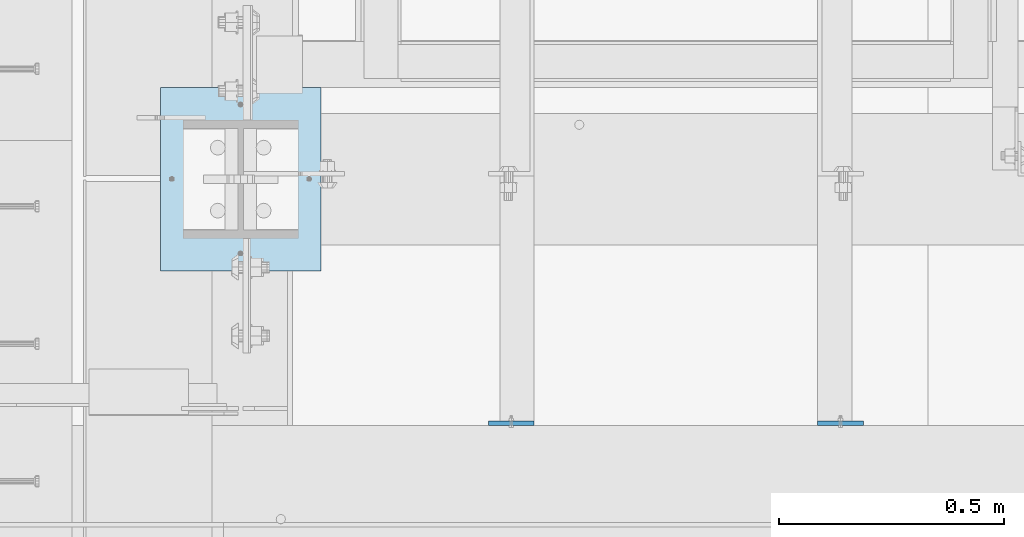
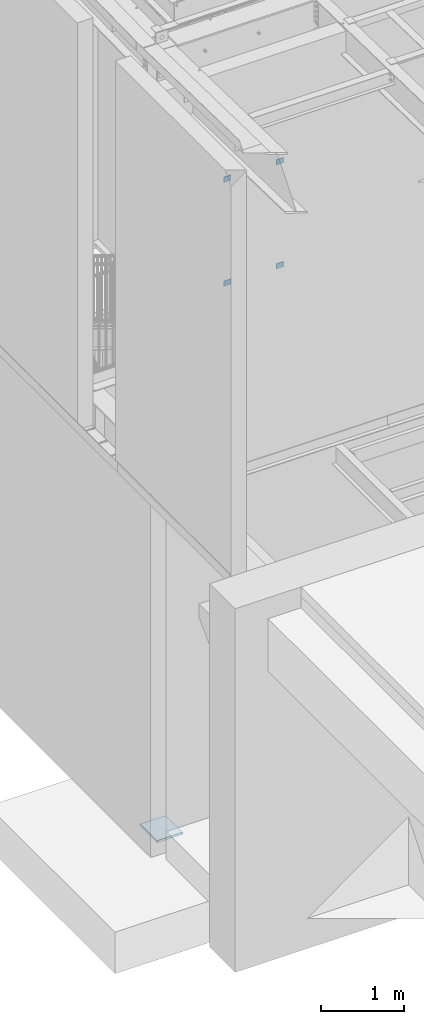
# One storey, part 1506 of 1763: 5 plates, 2 elements without a shape of their own.
"""IFC2X3 building model written with IfcOpenShell, lengths in millimetres."""

from ifc_helpers import new_model, si_unit, frame, origin_with_axes, place, context, subcontext, project, spatial, faceted_brep, material, type_object, element, aggregate, save


model = new_model("IFC2X3")

# Units and contexts
model_context = context("Model", 3, precision=1e-05, world=origin_with_axes())
body_context = subcontext(model_context, "Body", "Model", "MODEL_VIEW")
ifc_project = project(units=[si_unit("LENGTHUNIT", "METRE", prefix="MILLI"), si_unit("AREAUNIT", "SQUARE_METRE"), si_unit("VOLUMEUNIT", "CUBIC_METRE"), si_unit("MASSUNIT", "GRAM", prefix="KILO"), si_unit("TIMEUNIT", "SECOND"), si_unit("PLANEANGLEUNIT", "RADIAN"), si_unit("SOLIDANGLEUNIT", "STERADIAN"), si_unit("THERMODYNAMICTEMPERATUREUNIT", "DEGREE_CELSIUS"), si_unit("LUMINOUSINTENSITYUNIT", "LUMEN")], contexts=[model_context])

# Site, building, storey
site_placement = place(None, origin_with_axes())
site = spatial("IfcSite", under=ifc_project, at=site_placement, CompositionType="ELEMENT")
building_placement = place(site_placement, origin_with_axes())
building = spatial("IfcBuilding", under=site, at=building_placement, Name="Undefined", CompositionType="ELEMENT")
storey_placement = place(building_placement, origin_with_axes())
storey = spatial("IfcBuildingStorey", under=building, at=storey_placement, Name="Undefined", CompositionType="ELEMENT", Elevation=0.0)

# Assembly, plates
assembly_1_placement = place(storey_placement, origin_with_axes())
assembly_1 = element("IfcElementAssembly", 1, at=assembly_1_placement, inside=storey, Name="LADDER", AssemblyPlace="NOTDEFINED", PredefinedType="RIGID_FRAME")
ifc_material = material(Name="STEEL/A36")
plate_type_1 = type_object("IfcPlateType", PredefinedType="NOTDEFINED")
plate_1_placement = place(assembly_1_placement, frame((-86724.5624669171, 29481.4624999971, 9448.8), z_axis=(0.0, 0.0, -1.0), x_axis=(-1.0, 0.0, 0.0)))
plate_1 = element("IfcPlate", 2, at=plate_1_placement, type_object=plate_type_1, material=ifc_material, Name="PLATE", context=body_context, shape_type="Brep", body=[
    faceted_brep([(0.0, -4.76249999999982, 0.0), (0.0, -4.76250000000073, 76.1999969482422), (0.0, 4.76250000000073, 76.1999969482422), (0.0, 4.76249999999982, 0.0), (101.599990844727, -4.76250000000073, 76.1999969482422), (101.599990844727, 4.76250000000073, 76.1999969482422), (101.599990844727, -4.76250000000073, 0.0), (101.599990844727, 4.76250000000073, 0.0)], [[[0, 1, 2, 3]], [[1, 4, 5, 2]], [[4, 6, 7, 5]], [[6, 0, 3, 7]], [[5, 7, 3, 2]], [[6, 4, 1, 0]]]),
])
plate_2_placement = place(assembly_1_placement, frame((-86724.5624669171, 29481.4624999971, 7924.80000005696), z_axis=(0.0, 0.0, -1.0), x_axis=(-1.0, 0.0, 0.0)))
plate_2 = element("IfcPlate", 3, at=plate_2_placement, type_object=plate_type_1, material=ifc_material, Name="PLATE", context=body_context, shape_type="Brep", body=[
    faceted_brep([(0.0, -4.76249999999982, 0.0), (0.0, -4.76250000000073, 76.1999969482422), (0.0, 4.76250000000073, 76.1999969482422), (0.0, 4.76249999999982, 0.0), (101.599990844727, -4.76250000000073, 76.1999969482422), (101.599990844727, 4.76250000000073, 76.1999969482422), (101.599990844727, -4.76250000000073, 0.0), (101.599990844727, 4.76250000000073, 0.0)], [[[0, 1, 2, 3]], [[1, 4, 5, 2]], [[4, 6, 7, 5]], [[6, 0, 3, 7]], [[5, 7, 3, 2]], [[6, 4, 1, 0]]]),
])
plate_3_placement = place(assembly_1_placement, frame((-86095.9122617073, 29481.4624999971, 9448.8), z_axis=(0.0, 0.0, -1.0), x_axis=(1.0, 0.0, 0.0)))
plate_3 = element("IfcPlate", 4, at=plate_3_placement, type_object=plate_type_1, material=ifc_material, Name="PLATE", context=body_context, shape_type="Brep", body=[
    faceted_brep([(0.0, -4.76249999999982, 0.0), (0.0, -4.76250000000073, 76.1999969482422), (0.0, 4.76250000000073, 76.1999969482422), (0.0, 4.76249999999982, 0.0), (101.599990844727, -4.76250000000073, 76.1999969482422), (101.599990844727, 4.76250000000073, 76.1999969482422), (101.599990844727, -4.76250000000073, 0.0), (101.599990844727, 4.76250000000073, 0.0)], [[[0, 1, 2, 3]], [[1, 4, 5, 2]], [[4, 6, 7, 5]], [[6, 0, 3, 7]], [[5, 7, 3, 2]], [[6, 4, 1, 0]]]),
])
plate_4_placement = place(assembly_1_placement, frame((-86095.9122617073, 29481.4624999971, 7924.80000005696), z_axis=(0.0, 0.0, -1.0), x_axis=(1.0, 0.0, 0.0)))
plate_4 = element("IfcPlate", 5, at=plate_4_placement, type_object=plate_type_1, material=ifc_material, Name="PLATE", context=body_context, shape_type="Brep", body=[
    faceted_brep([(0.0, -4.76249999999982, 0.0), (0.0, -4.76250000000073, 76.1999969482422), (0.0, 4.76250000000073, 76.1999969482422), (0.0, 4.76249999999982, 0.0), (101.599990844727, -4.76250000000073, 76.1999969482422), (101.599990844727, 4.76250000000073, 76.1999969482422), (101.599990844727, -4.76250000000073, 0.0), (101.599990844727, 4.76250000000073, 0.0)], [[[0, 1, 2, 3]], [[1, 4, 5, 2]], [[4, 6, 7, 5]], [[6, 0, 3, 7]], [[5, 7, 3, 2]], [[6, 4, 1, 0]]]),
])
aggregate(assembly_1, [plate_1, plate_2, plate_3, plate_4])

# Assembly, plate
assembly_2_placement = place(storey_placement, origin_with_axes())
assembly_2 = element("IfcElementAssembly", 6, at=assembly_2_placement, inside=storey, Name="COLUMN", AssemblyPlace="NOTDEFINED", PredefinedType="RIGID_FRAME")
plate_type_2 = type_object("IfcPlateType", PredefinedType="NOTDEFINED")
plate_5_placement = place(assembly_2_placement, frame((-87553.2372736983, 30226.0, -250.824999999996), z_axis=(1.0, 0.0, 0.0), x_axis=(0.0, -1.0, 0.0)))
plate_5 = element("IfcPlate", 7, at=plate_5_placement, type_object=plate_type_2, material=ifc_material, Name="PLATE", context=body_context, shape_type="Brep", body=[
    faceted_brep([(0.0, -15.875, 0.0), (0.0, -15.875, 355.600006103516), (0.0, 15.875, 355.600006103516), (0.0, 15.875, 0.0), (406.399993896484, -15.875, 355.600006103516), (406.399993896484, 15.875, 355.600006103516), (406.399993896484, -15.875, 0.0), (406.399993896484, 15.875, 0.0)], [[[0, 1, 2, 3]], [[1, 4, 5, 2]], [[4, 6, 7, 5]], [[6, 0, 3, 7]], [[5, 7, 3, 2]], [[6, 4, 1, 0]]]),
])
aggregate(assembly_2, [plate_5])

save(model, "model.ifc")
